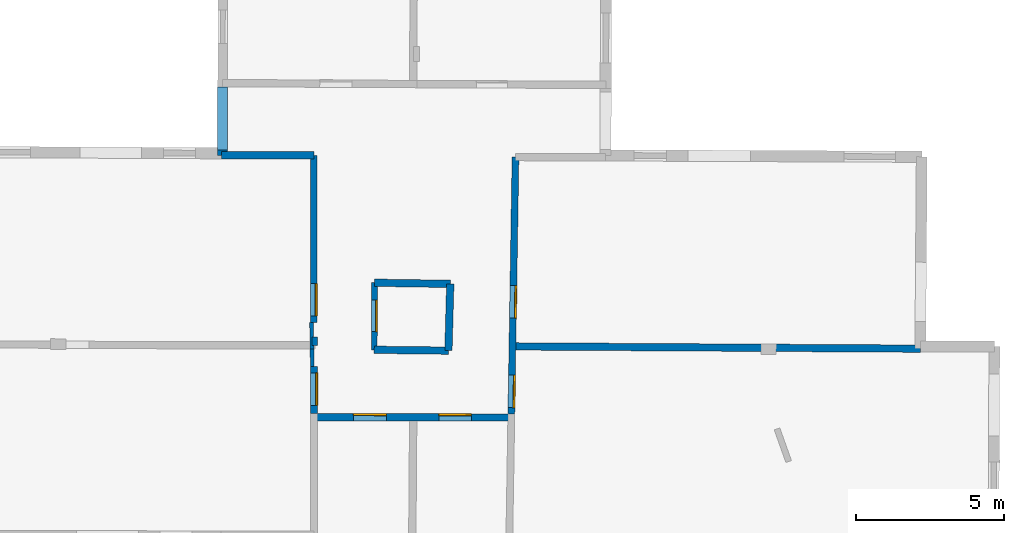
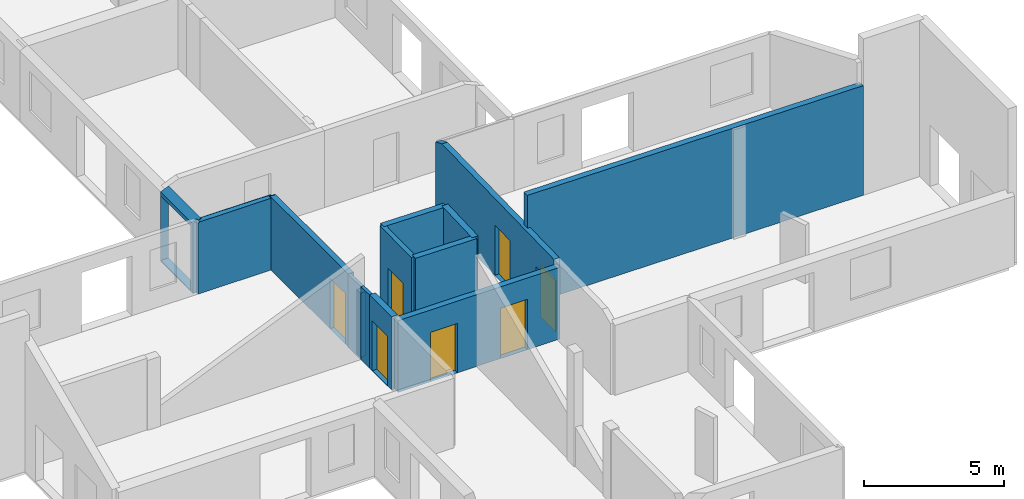
# One storey, part 3 of 10: 14 walls, 7 doors, 8 openings.
"""IFC2X3 building model written with IfcOpenShell, lengths in metres."""

from ifc_helpers import new_model, entity, si_unit, converted_unit, derived_unit, direction, frame, frame_2d, origin, origin_2d_with_axis, place, context, subcontext, project, spatial, polyline, rectangle, outline, extrude, clip, halfspace, source, transform, mapped, material, layer, layer_set, layer_usage, type_object, type_shapes, element, fill, save


model = new_model("IFC2X3")

# Units and contexts
model_context = context("Model", 3, precision=1e-05, world=origin(), true_north=direction((0.0, 1.0)))
body_context = subcontext(model_context, "Body", "Model", "MODEL_VIEW")
ifc_project = project(units=[si_unit("LENGTHUNIT", "METRE"), si_unit("AREAUNIT", "SQUARE_METRE"), si_unit("VOLUMEUNIT", "CUBIC_METRE"), converted_unit("PLANEANGLEUNIT", "DEGREE", entity("IfcRatioMeasure", 0.0174532925199433), si_unit("PLANEANGLEUNIT", "RADIAN"), dimensions=[0, 0, 0, 0, 0, 0, 0]), si_unit("MASSUNIT", "GRAM", prefix="KILO"), derived_unit("MASSDENSITYUNIT", [(si_unit("MASSUNIT", "GRAM", prefix="KILO"), 1), (si_unit("LENGTHUNIT", "METRE"), -3)]), derived_unit("MOMENTOFINERTIAUNIT", [(si_unit("LENGTHUNIT", "METRE"), 4)]), si_unit("TIMEUNIT", "SECOND"), si_unit("FREQUENCYUNIT", "HERTZ"), si_unit("THERMODYNAMICTEMPERATUREUNIT", "DEGREE_CELSIUS"), derived_unit("THERMALTRANSMITTANCEUNIT", [(si_unit("MASSUNIT", "GRAM", prefix="KILO"), 1), (si_unit("THERMODYNAMICTEMPERATUREUNIT", "KELVIN"), -1), (si_unit("TIMEUNIT", "SECOND"), -3)]), derived_unit("VOLUMETRICFLOWRATEUNIT", [(si_unit("LENGTHUNIT", "METRE"), 3), (si_unit("TIMEUNIT", "SECOND"), -1)]), si_unit("ELECTRICCURRENTUNIT", "AMPERE"), si_unit("ELECTRICVOLTAGEUNIT", "VOLT"), si_unit("POWERUNIT", "WATT"), si_unit("FORCEUNIT", "NEWTON", prefix="KILO"), si_unit("ILLUMINANCEUNIT", "LUX"), si_unit("LUMINOUSFLUXUNIT", "LUMEN"), si_unit("LUMINOUSINTENSITYUNIT", "CANDELA"), derived_unit("USERDEFINED", [(si_unit("MASSUNIT", "GRAM", prefix="KILO"), -1), (si_unit("LENGTHUNIT", "METRE"), -2), (si_unit("TIMEUNIT", "SECOND"), 3), (si_unit("LUMINOUSFLUXUNIT", "LUMEN"), 1)]), derived_unit("LINEARVELOCITYUNIT", [(si_unit("LENGTHUNIT", "METRE"), 1), (si_unit("TIMEUNIT", "SECOND"), -1)]), si_unit("PRESSUREUNIT", "PASCAL"), derived_unit("USERDEFINED", [(si_unit("LENGTHUNIT", "METRE"), -2), (si_unit("MASSUNIT", "GRAM", prefix="KILO"), 1), (si_unit("TIMEUNIT", "SECOND"), -2)]), derived_unit("LINEARFORCEUNIT", [(si_unit("MASSUNIT", "GRAM", prefix="KILO"), 1), (si_unit("LENGTHUNIT", "METRE"), 1), (si_unit("TIMEUNIT", "SECOND"), -2), (si_unit("LENGTHUNIT", "METRE"), -1)]), derived_unit("PLANARFORCEUNIT", [(si_unit("MASSUNIT", "GRAM", prefix="KILO"), 1), (si_unit("LENGTHUNIT", "METRE"), 1), (si_unit("TIMEUNIT", "SECOND"), -2), (si_unit("LENGTHUNIT", "METRE"), -2)])], contexts=[model_context])

# Site, building, storey
placement = place(None, origin())
site = spatial("IfcSite", under=ifc_project, at=placement, CompositionType="ELEMENT")
building = spatial("IfcBuilding", under=site, at=placement, CompositionType="ELEMENT")
storey_placement = place(placement, frame((0.0, 0.0, 15.2695512771606)))
storey = spatial("IfcBuildingStorey", under=building, at=storey_placement, Name="Level 6", CompositionType="ELEMENT", Elevation=15.2695512771606)

# Walls
ifc_material_1 = material(Name="Default wall")
ifc_layer_1 = layer(ifc_material_1, 0.25)
ifc_layer_set_1 = layer_set([ifc_layer_1], Name="wall_thickness_0.2500")
ifc_layer_usage_1 = layer_usage(ifc_layer_set_1, "AXIS2", "POSITIVE", -0.125)
wall_type_1 = type_object("IfcWallType", Name="wall_thickness_0.2500", PredefinedType="STANDARD", material=ifc_layer_set_1)
wall_1_placement = place(storey_placement, frame((4.88062187753366, 19.2992147880826, 0.0), z_axis=(0.0, 0.0, 1.0), x_axis=(0.99993473803398, -0.0114245206865004, 0.0)))
element("IfcWallStandardCase", 1, at=wall_1_placement, inside=storey, type_object=wall_type_1, material=ifc_layer_usage_1, Name="Wall:133", ObjectType="Wall", context=body_context, shape_type="Clipping", body=[
    clip(clip(extrude(outline(polyline([(2.51463373350694, -0.125), (2.51463373350694, 0.125), (0.0, 0.125), (0.0, -0.125), (2.51463373350694, -0.125)])), origin(), (0.0, 0.0, 1.0), 3.75044918060303), halfspace(frame((-16.9159832476651, 0.101464123891669, 5.79555813666937), z_axis=(0.000152136341881421, -0.389141476947962, 0.921177989192801), x_axis=(0.99999855630825, 0.00161820189688789, 0.000518463148508191)), False)), halfspace(frame((-6.78901658078438, 56.4707127470474, 2.60439273833051), z_axis=(-0.389888921884297, -0.00304006282565989, 0.920856876289642), x_axis=(0.920842582986298, 0.00497351168210678, 0.389902810378011)), False)),
])
wall_2_placement = place(storey_placement, frame((9.56299610584006, 19.4142570436021, 0.0), z_axis=(0.0, 0.0, 1.0), x_axis=(0.999984694651791, -0.00553267224436876, 0.0)))
element("IfcWallStandardCase", 2, at=wall_2_placement, inside=storey, type_object=wall_type_1, material=ifc_layer_usage_1, Name="Wall:161", ObjectType="Wall", context=body_context, shape_type="Clipping", body=[
    clip(extrude(outline(polyline([(13.8221157347284, -0.125), (13.8221157347284, 0.125), (0.0, 0.125), (0.0, -0.125), (13.8221157347284, -0.125)])), origin(), (0.0, 0.0, 1.0), 4.78644847869873), halfspace(frame((14.8175271157978, -0.0954444110205823, 5.89042703244326), z_axis=(0.00118553034659075, 0.389134350527478, 0.921180249330909), x_axis=(-0.999990732915869, 0.00427379011179484, -0.000518459702406836)), False)),
])
wall_3_placement = place(storey_placement, frame((7.45697118924506, 21.5324234576699, 0.0), z_axis=(0.0, 0.0, 1.0), x_axis=(-0.0273468884531701, -0.999626003909427, 0.0)))
element("IfcWallStandardCase", 3, at=wall_3_placement, inside=storey, type_object=wall_type_1, material=ifc_layer_usage_1, Name="Wall:171", ObjectType="Wall", context=body_context, shape_type="Clipping", body=[
    clip(clip(extrude(outline(polyline([(2.26278436760007, -0.125), (2.26278436760007, 0.125), (0.0, 0.125), (0.0, -0.125), (2.26278436760007, -0.125)])), origin(), (0.0, 0.0, 1.0), 3.75044918060303), halfspace(frame((1.83194549677856, 16.9792453628763, 5.89042703244326), z_axis=(-0.389067602125216, -0.00730405498193941, 0.921180249330909), x_axis=(0.0175428917095464, -0.999845977213493, -0.000518459702406836)), False)), halfspace(frame((-55.8299285400208, 3.83421246871149, 3.16730048752112), z_axis=(-0.00877574957602932, 0.390401501118395, 0.920602875372374), x_axis=(0.688704411973942, -0.665118682217615, 0.288623234499112)), False)),
])

# Wall, opening, door
wall_4_placement = place(storey_placement, frame((2.84138011921243, 18.730482548493, 0.0), z_axis=(0.0, 0.0, 1.0), x_axis=(-4.22098060487528e-05, -0.999999999109166, 0.0)))
wall_4 = element("IfcWallStandardCase", 4, at=wall_4_placement, inside=storey, type_object=wall_type_1, material=ifc_layer_usage_1, Name="Wall:192", ObjectType="Wall", context=body_context, shape_type="Clipping", body=[
    clip(clip(extrude(outline(polyline([(1.59285354756155, -0.125), (1.59285354756155, 0.125), (0.0, 0.125), (0.0, -0.125), (1.59285354756155, -0.125)])), origin(), (0.0, 0.0, 1.0), 3.19044971466064), halfspace(frame((-0.862818892663484, -14.8745147727065, 5.79555813666937), z_axis=(0.389117999781486, -0.00427720384871213, 0.921177989192801), x_axis=(0.00976420012366749, 0.999952194653279, 0.000518463148508191)), False)), halfspace(frame((-57.1131475697091, -4.10659167047372, 2.60439273833051), z_axis=(-0.0013979720993134, -0.389898267582831, 0.920856876289642), x_axis=(0.00550812958389377, 0.92083954029343, 0.38990281037801)), False)),
])
opening_1_placement = place(wall_4_placement, frame((0.210988999829915, -0.125, 0.00544929504394531)))
opening_1 = element("IfcOpeningElement", 5, at=opening_1_placement, cuts=wall_4, Name="Opening : 1100 x 2165 : 174", ObjectType="Opening", context=body_context, shape_type="SweptSolid", body=[
    extrude(rectangle(XDim=1.1, YDim=2.165, at=frame_2d((1.0825, 0.55), x_axis=(0.0, 1.0))), frame((0.0, 0.0, 0.0), z_axis=(0.0, 1.0, 0.0), x_axis=(0.0, 0.0, 1.0)), (0.0, 0.0, 1.0), 0.25),
])
ifc_material_2 = material(Name="Door Panel")
door_style_1 = type_object("IfcDoorStyle", Name="Door : 1100 x 2165mm", ConstructionType="NOTDEFINED", OperationType="SINGLE_SWING_RIGHT", ParameterTakesPrecedence=False, Sizeable=False, material=ifc_material_2)
shared_shape_1 = source(origin(), body_context, "Body", "SweptSolid", [
    extrude(rectangle(XDim=0.0625, YDim=1.1, at=origin_2d_with_axis()), frame((0.55, 0.21875, 0.0), z_axis=(0.0, 0.0, 1.0), x_axis=(0.0, 1.0, 0.0)), (0.0, 0.0, 1.0), 2.165),
])
type_shapes(door_style_1, [shared_shape_1])
door_1_placement = place(opening_1_placement, origin())
door_1 = element("IfcDoor", 6, at=door_1_placement, inside=storey, type_object=door_style_1, Name="Door : 1100 x 2165mm : 27", ObjectType="Door : 1100 x 2165mm", OverallHeight=2.165, OverallWidth=1.1, context=body_context, shape_type="MappedRepresentation", body=[
    mapped(shared_shape_1, transform((0.0, 0.0, 0.0), scale=1.0)),
])
fill(opening_1, door_1)

# Wall
wall_5_placement = place(storey_placement, frame((4.89204028881485, 21.5711583521998, 0.0), z_axis=(0.0, 0.0, 1.0), x_axis=(0.999885991157603, -0.0150998240644847, 0.0)))
element("IfcWallStandardCase", 7, at=wall_5_placement, inside=storey, type_object=wall_type_1, material=ifc_layer_usage_1, Name="Wall:194", ObjectType="Wall", context=body_context, shape_type="Clipping", body=[
    clip(clip(extrude(outline(polyline([(2.56522432776293, -0.125), (2.56522432776293, 0.125), (0.0, 0.125), (0.0, -0.125), (2.56522432776293, -0.125)])), origin(), (0.0, 0.0, 1.0), 3.75044918060303), halfspace(frame((19.520754202932, -2.03979738067989, 5.89042703244326), z_axis=(-0.00253758684870456, 0.389127882444358, 0.921180249330909), x_axis=(-0.999985852978793, -0.00529386832217402, -0.000518459702406836)), False)), halfspace(frame((-6.97364678704999, 54.1735204743474, 2.60439273833051), z_axis=(-0.389875114022532, -0.00447312597645417, 0.920856876289642), x_axis=(0.920818081847062, 0.00835814589644198, 0.389902810378011)), False)),
])

# Wall, openings, doors
wall_6_placement = place(storey_placement, frame((2.84130746738118, 17.0126286222707, 0.0), z_axis=(0.0, 0.0, 1.0), x_axis=(0.999999463875757, -0.00103549418078395, 0.0)))
wall_6 = element("IfcWallStandardCase", 8, at=wall_6_placement, inside=storey, type_object=wall_type_1, material=ifc_layer_usage_1, Name="Wall:216", ObjectType="Wall", context=body_context, shape_type="Clipping", body=[
    clip(clip(extrude(outline(polyline([(6.68266511609449, -0.125), (6.68266511609449, 0.125), (0.0, 0.125), (0.0, -0.125), (6.68266511609449, -0.125)])), origin(), (0.0, 0.0, 1.0), 3.13044834136963), halfspace(frame((-14.877070635498, 2.56589692407014, 5.79555813666937), z_axis=(-0.00389069690117937, -0.38912205630667, 0.921177989192801), x_axis=(0.99996139999742, -0.00877095839478101, 0.000518463148508191)), False)), halfspace(frame((9.91285009969065, 60.2342864113759, 3.16730048752112), z_axis=(0.390497243946479, -0.00149944200320734, 0.920602875372374), x_axis=(-0.683009438443611, -0.670965524825392, 0.288623234499112)), False)),
])
opening_2_placement = place(wall_6_placement, frame((1.33331986106637, -0.125, 0.00544929504394531)))
opening_2 = element("IfcOpeningElement", 9, at=opening_2_placement, cuts=wall_6, Name="Opening : 1115 x 2150 : 191", ObjectType="Opening", context=body_context, shape_type="SweptSolid", body=[
    extrude(rectangle(XDim=1.115, YDim=2.15, at=frame_2d((1.075, 0.5575), x_axis=(0.0, 1.0))), frame((0.0, 0.0, 0.0), z_axis=(0.0, 1.0, 0.0), x_axis=(0.0, 0.0, 1.0)), (0.0, 0.0, 1.0), 0.25),
])
opening_3_placement = place(wall_6_placement, frame((4.22731288266535, -0.125, 0.00544929504394531)))
opening_3 = element("IfcOpeningElement", 10, at=opening_3_placement, cuts=wall_6, Name="Opening : 1105 x 2195 : 192", ObjectType="Opening", context=body_context, shape_type="SweptSolid", body=[
    extrude(rectangle(XDim=1.105, YDim=2.195, at=frame_2d((1.0975, 0.5525), x_axis=(0.0, 1.0))), frame((0.0, 0.0, 0.0), z_axis=(0.0, 1.0, 0.0), x_axis=(0.0, 0.0, 1.0)), (0.0, 0.0, 1.0), 0.25),
])
door_style_2 = type_object("IfcDoorStyle", Name="Door : 1115 x 2150mm", ConstructionType="NOTDEFINED", OperationType="SINGLE_SWING_RIGHT", ParameterTakesPrecedence=False, Sizeable=False, material=ifc_material_2)
shared_shape_2 = source(origin(), body_context, "Body", "SweptSolid", [
    extrude(rectangle(XDim=0.0625, YDim=1.115, at=origin_2d_with_axis()), frame((0.5575, 0.21875, 0.0), z_axis=(0.0, 0.0, 1.0), x_axis=(0.0, 1.0, 0.0)), (0.0, 0.0, 1.0), 2.15),
])
type_shapes(door_style_2, [shared_shape_2])
door_2_placement = place(opening_2_placement, origin())
door_2 = element("IfcDoor", 11, at=door_2_placement, inside=storey, type_object=door_style_2, Name="Door : 1115 x 2150mm : 31", ObjectType="Door : 1115 x 2150mm", OverallHeight=2.15, OverallWidth=1.115, context=body_context, shape_type="MappedRepresentation", body=[
    mapped(shared_shape_2, transform((0.0, 0.0, 0.0), scale=1.0)),
])
fill(opening_2, door_2)
door_style_3 = type_object("IfcDoorStyle", Name="Door : 1105 x 2195mm", ConstructionType="NOTDEFINED", OperationType="SINGLE_SWING_RIGHT", ParameterTakesPrecedence=False, Sizeable=False, material=ifc_material_2)
shared_shape_3 = source(origin(), body_context, "Body", "SweptSolid", [
    extrude(rectangle(XDim=0.0625, YDim=1.105, at=origin_2d_with_axis()), frame((0.5525, 0.21875, 0.0), z_axis=(0.0, 0.0, 1.0), x_axis=(0.0, 1.0, 0.0)), (0.0, 0.0, 1.0), 2.195),
])
type_shapes(door_style_3, [shared_shape_3])
door_3_placement = place(opening_3_placement, origin())
door_3 = element("IfcDoor", 12, at=door_3_placement, inside=storey, type_object=door_style_3, Name="Door : 1105 x 2195mm : 32", ObjectType="Door : 1105 x 2195mm", OverallHeight=2.195, OverallWidth=1.105, context=body_context, shape_type="MappedRepresentation", body=[
    mapped(shared_shape_3, transform((0.0, 0.0, 0.0), scale=1.0)),
])
fill(opening_3, door_3)

# Wall
wall_7_placement = place(storey_placement, frame((-0.286999045675168, 25.8889331957748, 0.0), z_axis=(0.0, 0.0, 1.0), x_axis=(0.999999887381058, -0.000474592321164305, 0.0)))
element("IfcWallStandardCase", 13, at=wall_7_placement, inside=storey, type_object=wall_type_1, material=ifc_layer_usage_1, Name="Wall:229", ObjectType="Wall", context=body_context, shape_type="Clipping", body=[
    clip(clip(extrude(outline(polyline([(3.1186820204579, -0.125), (3.1186820204579, 0.125), (0.0, 0.125), (0.0, -0.125), (3.1186820204579, -0.125)])), origin(), (0.0, 0.0, 1.0), 3.13044834136963), halfspace(frame((24.6699216747128, -6.64039221583047, 5.89042703244326), z_axis=(0.00315379041101082, 0.389123376127274, 0.921180249330909), x_axis=(-0.99995632363241, 0.00933177513081764, -0.000518459702406836)), False)), halfspace(frame((-0.999509854958741, 49.9544014760967, 2.60439273833051), z_axis=(-0.389898835594882, 0.00122938677336944, 0.920856876289642), x_axis=(0.920841835834759, -0.00510997414856816, 0.389902810378011)), False)),
])

# Wall, opening
ifc_layer_2 = layer(ifc_material_1, 0.330000013113022)
ifc_layer_set_2 = layer_set([ifc_layer_2], Name="wall_thickness_0.3300")
ifc_layer_usage_2 = layer_usage(ifc_layer_set_2, "AXIS2", "POSITIVE", -0.165000006556511)
wall_type_2 = type_object("IfcWallType", Name="wall_thickness_0.3300", PredefinedType="STANDARD", material=ifc_layer_set_2)
wall_8_placement = place(storey_placement, frame((-0.257213331262723, 28.2079072558955, 0.0), z_axis=(0.0, 0.0, 1.0), x_axis=(-0.00325150118151647, -0.999994713856062, 0.0)))
wall_8 = element("IfcWallStandardCase", 14, at=wall_8_placement, inside=storey, type_object=wall_type_2, material=ifc_layer_usage_2, Name="Wall:184", ObjectType="Wall", context=body_context, shape_type="Clipping", body=[
    clip(extrude(outline(polyline([(2.31900296598093, -0.165000006556511), (2.31900296598093, 0.165000006556511), (0.0, 0.165000006556511), (0.0, -0.165000006556511), (2.31900296598093, -0.165000006556511)])), origin(), (0.0, 0.0, 1.0), 3.19044971466064), halfspace(frame((-47.6323746707785, -1.16047033839224, 2.60439273833051), z_axis=(-0.000146667666720429, -0.389900746188923, 0.920856876289642), x_axis=(0.00255285862053689, 0.920852475357586, 0.389902810378011)), False)),
])
opening_4_placement = place(wall_8_placement, frame((0.0020809284777685, -0.165000006556511, 0.0334491729736328)))
element("IfcOpeningElement", 15, at=opening_4_placement, cuts=wall_8, Name="Opening : 2140 x 2820 : 165", ObjectType="Opening", context=body_context, shape_type="SweptSolid", body=[
    extrude(rectangle(XDim=2.14, YDim=2.82, at=frame_2d((1.41, 1.07), x_axis=(0.0, 1.0))), frame((0.0, 0.0, 0.0), z_axis=(0.0, 1.0, 0.0), x_axis=(0.0, 0.0, 1.0)), (0.0, 0.0, 1.0), 0.330000013113022),
])

# Wall
ifc_layer_3 = layer(ifc_material_1, 0.2)
ifc_layer_set_3 = layer_set([ifc_layer_3], Name="wall_thickness_0.2000")
ifc_layer_usage_3 = layer_usage(ifc_layer_set_3, "AXIS2", "POSITIVE", -0.1)
wall_type_3 = type_object("IfcWallType", Name="wall_thickness_0.2000", PredefinedType="STANDARD", material=ifc_layer_set_3)
wall_9_placement = place(storey_placement, frame((2.86537811626608, 19.7331553988814, 0.0), z_axis=(0.0, 0.0, 1.0), x_axis=(0.00330807712119503, -0.99999452829791, 0.0)))
element("IfcWallStandardCase", 16, at=wall_9_placement, inside=storey, type_object=wall_type_3, material=ifc_layer_usage_3, Name="Wall:125", ObjectType="Wall", context=body_context, shape_type="Clipping", body=[
    clip(clip(extrude(outline(polyline([(0.284034375806761, -0.1), (0.284034375806761, 0.1), (0.0, 0.1), (0.0, -0.1), (0.284034375806761, -0.1)])), origin(), (0.0, 0.0, 1.0), 2.80144786834717), halfspace(frame((0.567490372948636, 21.5126306641029, 5.89042703244326), z_axis=(-0.389108662481379, 0.0046256917965507, 0.921180249330909), x_axis=(-0.0131142096282682, -0.999913870643548, -0.000518459702406835)), False)), halfspace(frame((-56.1239973203975, -3.94253798989508, 2.60439273833051), z_axis=(-0.00270423523121573, -0.389891395778232, 0.920856876289642), x_axis=(0.00859317512956802, 0.920815918520375, 0.389902810378011)), False)),
])

# Wall, opening, door
wall_10_placement = place(storey_placement, frame((4.89204051553432, 21.5711583978001, 0.0), z_axis=(0.0, 0.0, 1.0), x_axis=(-0.00502594913195623, -0.999987369837901, 0.0)))
wall_10 = element("IfcWallStandardCase", 17, at=wall_10_placement, inside=storey, type_object=wall_type_3, material=ifc_layer_usage_3, Name="Wall:221", ObjectType="Wall", context=body_context, shape_type="Clipping", body=[
    clip(clip(extrude(outline(polyline([(2.27197274140452, -0.1), (2.27197274140452, 0.1), (0.0, 0.1), (0.0, -0.1), (2.27197274140452, -0.1)])), origin(), (0.0, 0.0, 1.0), 3.75044918060303), halfspace(frame((2.23635101360959, 19.4992139207159, 5.89042703244326), z_axis=(-0.38913369982342, 0.00138271630521842, 0.921180249330909), x_axis=(-0.0047805150249483, -0.999988438870987, -0.000518459702406835)), False)), halfspace(frame((-54.2410256162265, -6.42753514467864, 2.60439273833051), z_axis=(0.0005451967973457, -0.389900392601156, 0.920856876289642), x_axis=(0.000918836462330002, 0.920855555556291, 0.389902810378011)), False)),
])
opening_5_placement = place(wall_10_placement, frame((0.585210561169678, -0.1, 0.00544929504394531)))
opening_5 = element("IfcOpeningElement", 18, at=opening_5_placement, cuts=wall_10, Name="Opening : 1075 x 2255 : 199", ObjectType="Opening", context=body_context, shape_type="SweptSolid", body=[
    extrude(rectangle(XDim=1.075, YDim=2.255, at=frame_2d((1.1275, 0.5375), x_axis=(0.0, 1.0))), frame((0.0, 0.0, 0.0), z_axis=(0.0, 1.0, 0.0), x_axis=(0.0, 0.0, 1.0)), (0.0, 0.0, 1.0), 0.2),
])
door_style_4 = type_object("IfcDoorStyle", Name="Door : 1075 x 2255mm", ConstructionType="NOTDEFINED", OperationType="SINGLE_SWING_RIGHT", ParameterTakesPrecedence=False, Sizeable=False, material=ifc_material_2)
shared_shape_4 = source(origin(), body_context, "Body", "SweptSolid", [
    extrude(rectangle(XDim=0.05, YDim=1.075, at=origin_2d_with_axis()), frame((0.5375, 0.175, 0.0), z_axis=(0.0, 0.0, 1.0), x_axis=(0.0, 1.0, 0.0)), (0.0, 0.0, 1.0), 2.255),
])
type_shapes(door_style_4, [shared_shape_4])
door_4_placement = place(opening_5_placement, origin())
door_4 = element("IfcDoor", 19, at=door_4_placement, inside=storey, type_object=door_style_4, Name="Door : 1075 x 2255mm : 33", ObjectType="Door : 1075 x 2255mm", OverallHeight=2.255, OverallWidth=1.075, context=body_context, shape_type="MappedRepresentation", body=[
    mapped(shared_shape_4, transform((0.0, 0.0, 0.0), scale=1.0)),
])
fill(opening_5, door_4)

# Walls
ifc_layer_4 = layer(ifc_material_1, 0.129999995231628)
ifc_layer_set_4 = layer_set([ifc_layer_4], Name="wall_thickness_0.1300")
ifc_layer_usage_4 = layer_usage(ifc_layer_set_4, "AXIS2", "POSITIVE", -0.0649999976158142)
wall_type_4 = type_object("IfcWallType", Name="wall_thickness_0.1300", PredefinedType="STANDARD", material=ifc_layer_set_4)
wall_11_placement = place(storey_placement, frame((2.75760795947066, 20.2262015186017, 0.0), z_axis=(0.0, 0.0, 1.0), x_axis=(0.0168802965477004, -0.99985751764362, 0.0)))
element("IfcWallStandardCase", 20, at=wall_11_placement, inside=storey, type_object=wall_type_4, material=ifc_layer_usage_4, Name="Wall:139", ObjectType="Wall", context=body_context, shape_type="Clipping", body=[
    clip(clip(extrude(outline(polyline([(0.903248737902128, -0.0649999976158142), (0.903248737902128, 0.0649999976158142), (0.0, 0.0649999976158142), (0.0, -0.0649999976158142), (0.903248737902128, -0.0649999976158142)])), origin(), (0.0, 0.0, 1.0), 3.19044971466064), halfspace(frame((1.35421545849607, 21.6023788114189, 5.89042703244326), z_axis=(-0.389010038264265, 0.00990648132686574, 0.921180249330909), x_axis=(-0.0266844310587762, -0.999643772720366, -0.000518459702406835)), False)), halfspace(frame((-55.6775430525045, -3.08099432174925, 2.60439273833051), z_axis=(-0.00799582547534999, -0.389818778620337, 0.920856876289642), x_axis=(0.0210902482625661, 0.920614468649908, 0.389902810378011)), False)),
])
wall_12_placement = place(storey_placement, frame((2.77285506602279, 19.3230814777081, 0.0), z_axis=(0.0, 0.0, 1.0), x_axis=(0.0168804003929521, -0.999857515890426, 0.0)))
element("IfcWallStandardCase", 21, at=wall_12_placement, inside=storey, type_object=wall_type_4, material=ifc_layer_usage_4, Name="Wall:140", ObjectType="Wall", context=body_context, shape_type="Clipping", body=[
    clip(clip(extrude(outline(polyline([(0.591555005572022, -0.0649999976158142), (0.591555005572022, 0.0649999976158142), (0.0, 0.0649999976158142), (0.0, -0.0649999976158142), (0.591555005572022, -0.0649999976158142)])), origin(), (0.0, 0.0, 1.0), 3.19044971466064), halfspace(frame((-0.52073964123522, -14.7992716542474, 5.79555813666937), z_axis=(0.388989897621748, -0.0108614812493557, 0.921177989192801), x_axis=(0.0266845970932144, 0.999643768286451, 0.000518463148508191)), False)), halfspace(frame((-56.5807921103986, -3.08098844526536, 2.60439273833051), z_axis=(-0.00799586596194783, -0.389818777789888, 0.920856876289642), x_axis=(0.0210903438776351, 0.920614466459469, 0.38990281037801)), False)),
])

# Wall, openings, doors
ifc_layer_5 = layer(ifc_material_1, 0.230000004172325)
ifc_layer_set_5 = layer_set([ifc_layer_5], Name="wall_thickness_0.2300")
ifc_layer_usage_5 = layer_usage(ifc_layer_set_5, "AXIS2", "POSITIVE", -0.115000002086163)
wall_type_5 = type_object("IfcWallType", Name="wall_thickness_0.2300", PredefinedType="STANDARD", material=ifc_layer_set_5)
wall_13_placement = place(storey_placement, frame((9.66698416499445, 25.8311079441987, 0.0), z_axis=(0.0, 0.0, 1.0), x_axis=(-0.0162027390434622, -0.999868727007445, 0.0)))
wall_13 = element("IfcWallStandardCase", 22, at=wall_13_placement, inside=storey, type_object=wall_type_5, material=ifc_layer_usage_5, Name="Wall:163", ObjectType="Wall", context=body_context, shape_type="Clipping", body=[
    clip(clip(extrude(outline(polyline([(8.70157219780417, -0.115000002086163), (8.70157219780417, 0.115000002086163), (0.0, 0.115000002086163), (0.0, -0.115000002086163), (8.70157219780417, -0.115000002086163)])), origin(), (0.0, 0.0, 1.0), 3.35544872283936), halfspace(frame((6.35502131857834, 14.8176981222034, 5.89042703244326), z_axis=(-0.389124846629639, -0.00296681278553021, 0.921180249330909), x_axis=(0.00639689941927457, -0.999979405226606, -0.000518459702406835)), False)), halfspace(frame((-51.4497931228951, 2.31621682552449, 3.16730048752112), z_axis=(-0.0044235474856598, 0.390475067173, 0.920602875372374), x_axis=(0.681247801159378, -0.672754087258327, 0.288623234499112)), False)),
])
opening_6_placement = place(wall_13_placement, frame((4.35833735617753, -0.115000002086163, 0.00544929504394531)))
opening_6 = element("IfcOpeningElement", 23, at=opening_6_placement, cuts=wall_13, Name="Opening : 1100 x 2195 : 149", ObjectType="Opening", context=body_context, shape_type="SweptSolid", body=[
    extrude(rectangle(XDim=1.1, YDim=2.195, at=frame_2d((1.0975, 0.55), x_axis=(0.0, 1.0))), frame((0.0, 0.0, 0.0), z_axis=(0.0, 1.0, 0.0), x_axis=(0.0, 0.0, 1.0)), (0.0, 0.0, 1.0), 0.230000004172325),
])
opening_7_placement = place(wall_13_placement, frame((7.39118140318924, -0.115000002086163, 0.0124492645263672)))
opening_7 = element("IfcOpeningElement", 24, at=opening_7_placement, cuts=wall_13, Name="Opening : 1105 x 2230 : 150", ObjectType="Opening", context=body_context, shape_type="SweptSolid", body=[
    extrude(rectangle(XDim=1.105, YDim=2.23, at=frame_2d((1.115, 0.5525), x_axis=(0.0, 1.0))), frame((0.0, 0.0, 0.0), z_axis=(0.0, 1.0, 0.0), x_axis=(0.0, 0.0, 1.0)), (0.0, 0.0, 1.0), 0.230000004172325),
])
door_style_5 = type_object("IfcDoorStyle", Name="Door : 1100 x 2195mm", ConstructionType="NOTDEFINED", OperationType="SINGLE_SWING_RIGHT", ParameterTakesPrecedence=False, Sizeable=False, material=ifc_material_2)
shared_shape_5 = source(origin(), body_context, "Body", "SweptSolid", [
    extrude(rectangle(XDim=0.0575000010430813, YDim=1.1, at=origin_2d_with_axis()), frame((0.55, 0.201250003650784, 0.0), z_axis=(0.0, 0.0, 1.0), x_axis=(0.0, 1.0, 0.0)), (0.0, 0.0, 1.0), 2.195),
])
type_shapes(door_style_5, [shared_shape_5])
door_5_placement = place(opening_6_placement, origin())
door_5 = element("IfcDoor", 25, at=door_5_placement, inside=storey, type_object=door_style_5, Name="Door : 1100 x 2195mm : 24", ObjectType="Door : 1100 x 2195mm", OverallHeight=2.195, OverallWidth=1.1, context=body_context, shape_type="MappedRepresentation", body=[
    mapped(shared_shape_5, transform((0.0, 0.0, 0.0), scale=1.0)),
])
fill(opening_6, door_5)
door_style_6 = type_object("IfcDoorStyle", Name="Door : 1105 x 2230mm", ConstructionType="NOTDEFINED", OperationType="SINGLE_SWING_RIGHT", ParameterTakesPrecedence=False, Sizeable=False, material=ifc_material_2)
shared_shape_6 = source(origin(), body_context, "Body", "SweptSolid", [
    extrude(rectangle(XDim=0.0575000010430813, YDim=1.105, at=origin_2d_with_axis()), frame((0.5525, 0.201250003650784, 0.0), z_axis=(0.0, 0.0, 1.0), x_axis=(0.0, 1.0, 0.0)), (0.0, 0.0, 1.0), 2.23),
])
type_shapes(door_style_6, [shared_shape_6])
door_6_placement = place(opening_7_placement, origin())
door_6 = element("IfcDoor", 26, at=door_6_placement, inside=storey, type_object=door_style_6, Name="Door : 1105 x 2230mm : 25", ObjectType="Door : 1105 x 2230mm", OverallHeight=2.23, OverallWidth=1.105, context=body_context, shape_type="MappedRepresentation", body=[
    mapped(shared_shape_6, transform((0.0, 0.0, 0.0), scale=1.0)),
])
fill(opening_7, door_6)

# Wall, opening, door
wall_14_placement = place(storey_placement, frame((2.83168219764707, 25.8874539447199, 0.0), z_axis=(0.0, 0.0, 1.0), x_axis=(-4.21931120253271e-05, -0.999999999109871, 0.0)))
wall_14 = element("IfcWallStandardCase", 27, at=wall_14_placement, inside=storey, type_object=wall_type_5, material=ifc_layer_usage_5, Name="Wall:191", ObjectType="Wall", context=body_context, shape_type="Clipping", body=[
    clip(clip(extrude(outline(polyline([(5.66195297745198, -0.115000002086163), (5.66195297745198, 0.115000002086163), (0.0, 0.115000002086163), (0.0, -0.115000002086163), (5.66195297745198, -0.115000002086163)])), origin(), (0.0, 0.0, 1.0), 3.19044971466064), halfspace(frame((6.6497111855984, 21.5483667651248, 5.89042703244326), z_axis=(-0.389121976053759, 0.00332204675795968, 0.921180249330909), x_axis=(-0.00976415458628207, -0.999952195099722, -0.000518459702406835)), False)), halfspace(frame((-49.9561766575939, -4.09659082057289, 2.60439273833051), z_axis=(-0.00139797860828416, -0.389898267559494, 0.920856876289642), x_axis=(0.00550814495640954, 0.920839540201478, 0.389902810378011)), False)),
])
opening_8_placement = place(wall_14_placement, frame((4.34695434522794, -0.115000002086163, 0.00544929504394531)))
opening_8 = element("IfcOpeningElement", 28, at=opening_8_placement, cuts=wall_14, Name="Opening : 1095 x 2210 : 173", ObjectType="Opening", context=body_context, shape_type="SweptSolid", body=[
    extrude(rectangle(XDim=1.095, YDim=2.21, at=frame_2d((1.105, 0.5475), x_axis=(0.0, 1.0))), frame((0.0, 0.0, 0.0), z_axis=(0.0, 1.0, 0.0), x_axis=(0.0, 0.0, 1.0)), (0.0, 0.0, 1.0), 0.230000004172325),
])
door_style_7 = type_object("IfcDoorStyle", Name="Door : 1095 x 2210mm", ConstructionType="NOTDEFINED", OperationType="SINGLE_SWING_RIGHT", ParameterTakesPrecedence=False, Sizeable=False, material=ifc_material_2)
shared_shape_7 = source(origin(), body_context, "Body", "SweptSolid", [
    extrude(rectangle(XDim=0.0575000010430813, YDim=1.095, at=origin_2d_with_axis()), frame((0.5475, 0.201250003650784, 0.0), z_axis=(0.0, 0.0, 1.0), x_axis=(0.0, 1.0, 0.0)), (0.0, 0.0, 1.0), 2.21),
])
type_shapes(door_style_7, [shared_shape_7])
door_7_placement = place(opening_8_placement, origin())
door_7 = element("IfcDoor", 29, at=door_7_placement, inside=storey, type_object=door_style_7, Name="Door : 1095 x 2210mm : 26", ObjectType="Door : 1095 x 2210mm", OverallHeight=2.21, OverallWidth=1.095, context=body_context, shape_type="MappedRepresentation", body=[
    mapped(shared_shape_7, transform((0.0, 0.0, 0.0), scale=1.0)),
])
fill(opening_8, door_7)

save(model, "model.ifc")
